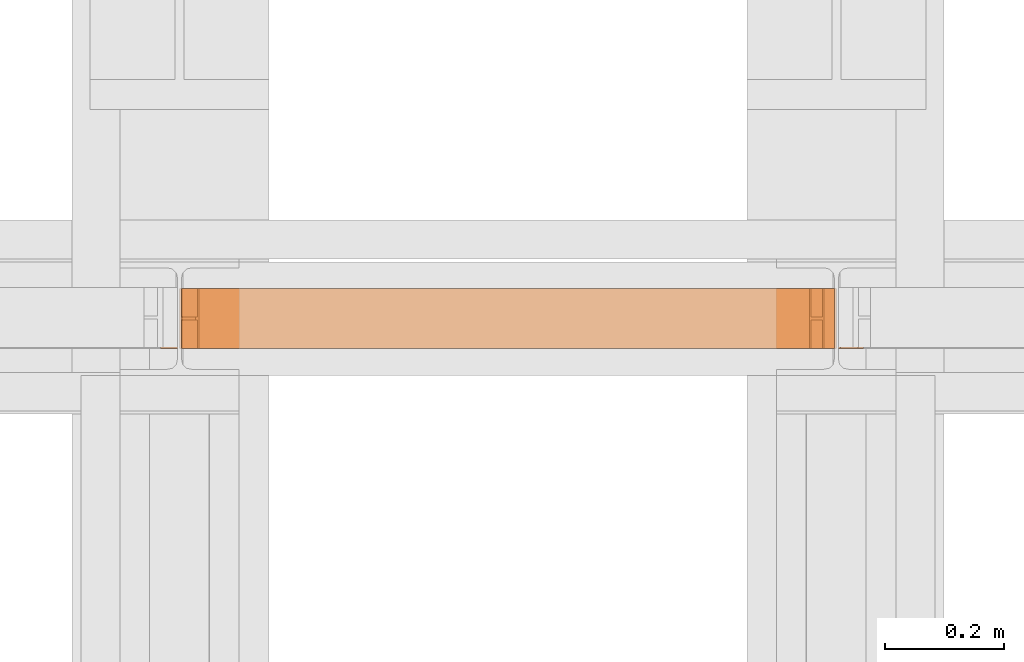
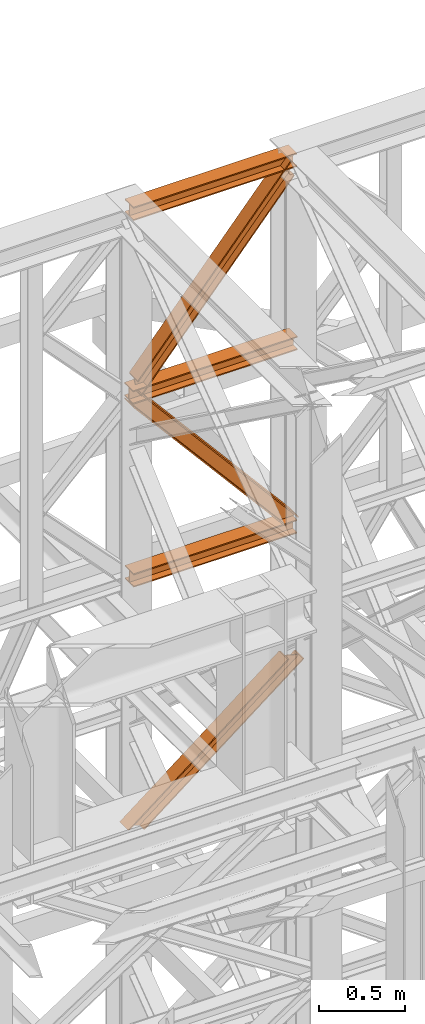
# One storey, part 172 of 208: 6 proxies.
"""IFC2X3 building model written with IfcOpenShell, lengths in millimetres."""

from ifc_helpers import new_model, entity, si_unit, converted_unit, frame, origin, origin_with_axes, place, context, subcontext, project, spatial, faceted_brep, element, save


model = new_model("IFC2X3")

# Units and contexts
model_context = context("Model", 3, precision=1e-05, world=origin())
plan_context = context("Plan", 3, precision=1e-05, world=origin())
body_context = subcontext(model_context, "Body", "Model", "MODEL_VIEW")
ifc_project = project(units=[si_unit("LENGTHUNIT", "METRE", prefix="MILLI"), converted_unit("PLANEANGLEUNIT", "DEGREE", entity("IfcPlaneAngleMeasure", 0.0174532925199433), si_unit("PLANEANGLEUNIT", "RADIAN"), dimensions=[0, 0, 0, 0, 0, 0, 0]), si_unit("AREAUNIT", "SQUARE_METRE"), si_unit("VOLUMEUNIT", "CUBIC_METRE")], contexts=[model_context, plan_context])

# Building, storey
building_placement = place(None, origin())
building = spatial("IfcBuilding", under=ifc_project, at=building_placement, CompositionType="COMPLEX")
storey_placement = place(building_placement, origin_with_axes())
storey = spatial("IfcBuildingStorey", under=building, at=storey_placement, Name="Geschoss", CompositionType="ELEMENT")

# Proxies
proxy_1_placement = place(storey_placement, frame((5498.369516902634, -13812.50587051042, 9710.105713222341), z_axis=(0.0, 0.0, 1.0), x_axis=(1.0, 0.0, 0.0)))
element("IfcBuildingElementProxy", 1, at=proxy_1_placement, inside=storey, context=body_context, shape_type="Brep", body=[
    faceted_brep([(1091.936120735611, 0.01000000000021828, 88.01000000000022), (1091.936120735611, 0.01000000000021828, 96.01000000000022), (1091.936120735611, 100.0100000000002, 96.01000000000022), (1091.936120735611, 100.0100000000002, 88.01000000000022), (1091.936120735611, 52.51000000000022, 88.01000000000022), (1091.936120735611, 52.51000000000022, 8.010000000000218), (1091.936120735611, 100.0100000000002, 8.010000000000218), (1091.936120735611, 100.0100000000002, 0.01000000000021828), (1091.936120735611, 0.01000000000021828, 0.01000000000021828), (1091.936120735611, 0.01000000000021828, 8.010000000000218), (1091.936120735611, 47.51000000000022, 8.010000000000218), (1091.936120735611, 47.51000000000022, 88.01000000000022), (1091.936120735611, 0.01000000000021828, 96.01000000000022), (1091.936120735611, 0.01000000000021828, 88.01000000000022), (0.009999999999308784, 0.01000000000385626, 88.01000000000022), (0.009999999999308784, 0.01000000000385626, 96.01000000000022), (1091.936120735611, 100.0100000000002, 96.01000000000022), (1091.936120735611, 0.01000000000021828, 96.01000000000022), (0.009999999999308784, 0.01000000000385626, 96.01000000000022), (0.009999999999308784, 100.0100000000039, 96.01000000000022), (1091.936120735611, 100.0100000000002, 88.01000000000022), (1091.936120735611, 100.0100000000002, 96.01000000000022), (0.009999999999308784, 100.0100000000039, 96.01000000000022), (0.009999999999308784, 100.0100000000039, 88.01000000000022), (1091.936120735611, 52.51000000000022, 88.01000000000022), (1091.936120735611, 100.0100000000002, 88.01000000000022), (0.009999999999308784, 100.0100000000039, 88.01000000000022), (0.009999999999308784, 52.51000000000386, 88.01000000000022), (1091.936120735611, 52.51000000000022, 8.010000000000218), (1091.936120735611, 52.51000000000022, 88.01000000000022), (0.009999999999308784, 52.51000000000386, 88.01000000000022), (0.009999999999308784, 52.51000000000386, 8.010000000000218), (1091.936120735611, 100.0100000000002, 8.010000000000218), (1091.936120735611, 52.51000000000022, 8.010000000000218), (0.009999999999308784, 52.51000000000386, 8.010000000000218), (0.009999999999308784, 100.0100000000039, 8.010000000000218), (1091.936120735611, 100.0100000000002, 0.01000000000021828), (1091.936120735611, 100.0100000000002, 8.010000000000218), (0.009999999999308784, 100.0100000000039, 8.010000000000218), (0.009999999999308784, 100.0100000000039, 0.01000000000021828), (1091.936120735611, 0.01000000000021828, 0.01000000000021828), (1091.936120735611, 100.0100000000002, 0.01000000000021828), (0.009999999999308784, 100.0100000000039, 0.01000000000021828), (0.009999999999308784, 0.01000000000385626, 0.01000000000021828), (1091.936120735611, 0.01000000000021828, 8.010000000000218), (1091.936120735611, 0.01000000000021828, 0.01000000000021828), (0.009999999999308784, 0.01000000000385626, 0.01000000000021828), (0.009999999999308784, 0.01000000000385626, 8.010000000000218), (1091.936120735611, 47.51000000000022, 8.010000000000218), (1091.936120735611, 0.01000000000021828, 8.010000000000218), (0.009999999999308784, 0.01000000000385626, 8.010000000000218), (0.009999999999308784, 47.51000000000386, 8.010000000000218), (1091.936120735611, 47.51000000000022, 88.01000000000022), (1091.936120735611, 47.51000000000022, 8.010000000000218), (0.009999999999308784, 47.51000000000386, 8.010000000000218), (0.009999999999308784, 47.51000000000386, 88.01000000000022), (1091.936120735611, 0.01000000000021828, 88.01000000000022), (1091.936120735611, 47.51000000000022, 88.01000000000022), (0.009999999999308784, 47.51000000000386, 88.01000000000022), (0.009999999999308784, 0.01000000000385626, 88.01000000000022), (0.009999999999308784, 0.01000000000385626, 88.01000000000022), (0.009999999999308784, 47.51000000000386, 88.01000000000022), (0.009999999999308784, 47.51000000000386, 8.010000000000218), (0.009999999999308784, 0.01000000000385626, 8.010000000000218), (0.009999999999308784, 0.01000000000385626, 0.01000000000021828), (0.009999999999308784, 100.0100000000039, 0.01000000000021828), (0.009999999999308784, 100.0100000000039, 8.010000000000218), (0.009999999999308784, 52.51000000000386, 8.010000000000218), (0.009999999999308784, 52.51000000000386, 88.01000000000022), (0.009999999999308784, 100.0100000000039, 88.01000000000022), (0.009999999999308784, 100.0100000000039, 96.01000000000022), (0.009999999999308784, 0.01000000000385626, 96.01000000000022)], [[[0, 1, 2, 3, 4, 5, 6, 7, 8, 9, 10, 11]], [[12, 13, 14, 15]], [[16, 17, 18, 19]], [[20, 21, 22, 23]], [[24, 25, 26, 27]], [[28, 29, 30, 31]], [[32, 33, 34, 35]], [[36, 37, 38, 39]], [[40, 41, 42, 43]], [[44, 45, 46, 47]], [[48, 49, 50, 51]], [[52, 53, 54, 55]], [[56, 57, 58, 59]], [[60, 61, 62, 63, 64, 65, 66, 67, 68, 69, 70, 71]]], orient=[[False], [False], [False], [False], [False], [False], [False], [False], [False], [False], [False], [False], [False], [False]]),
])
proxy_2_placement = place(storey_placement, frame((5496.504968595721, -13812.50587051042, 12300.47045114381), z_axis=(0.0, 0.0, 1.0), x_axis=(1.0, 0.0, 0.0)))
element("IfcBuildingElementProxy", 2, at=proxy_2_placement, inside=storey, context=body_context, shape_type="Brep", body=[
    faceted_brep([(1093.509999865889, 0.01000000000021828, 88.01000000000022), (1093.509999865889, 0.01000000000021828, 96.01000000000022), (1093.509999865889, 100.0100000000002, 96.01000000000022), (1093.509999865889, 100.0100000000002, 88.01000000000022), (1093.509999865889, 52.51000000000022, 88.01000000000022), (1093.509999865889, 52.51000000000022, 8.010000000000218), (1093.509999865889, 100.0100000000002, 8.010000000000218), (1093.509999865889, 100.0100000000002, 0.01000000000021828), (1093.509999865889, 0.01000000000021828, 0.01000000000021828), (1093.509999865889, 0.01000000000021828, 8.010000000000218), (1093.509999865889, 47.51000000000022, 8.010000000000218), (1093.509999865889, 47.51000000000022, 88.01000000000022), (1093.509999865889, 0.01000000000021828, 96.01000000000022), (1093.509999865889, 0.01000000000021828, 88.01000000000022), (0.01000000000021828, 0.01000000000385626, 88.01000000000022), (0.01000000000021828, 0.01000000000385626, 96.01000000000022), (1093.509999865889, 100.0100000000002, 96.01000000000022), (1093.509999865889, 0.01000000000021828, 96.01000000000022), (0.01000000000021828, 0.01000000000385626, 96.01000000000022), (0.01000000000021828, 100.0100000000039, 96.01000000000022), (1093.509999865889, 100.0100000000002, 88.01000000000022), (1093.509999865889, 100.0100000000002, 96.01000000000022), (0.01000000000021828, 100.0100000000039, 96.01000000000022), (0.01000000000021828, 100.0100000000039, 88.01000000000022), (1093.509999865889, 52.51000000000022, 88.01000000000022), (1093.509999865889, 100.0100000000002, 88.01000000000022), (0.01000000000021828, 100.0100000000039, 88.01000000000022), (0.01000000000021828, 52.51000000000386, 88.01000000000022), (1093.509999865889, 52.51000000000022, 8.010000000000218), (1093.509999865889, 52.51000000000022, 88.01000000000022), (0.01000000000021828, 52.51000000000386, 88.01000000000022), (0.01000000000021828, 52.51000000000386, 8.010000000000218), (1093.509999865889, 100.0100000000002, 8.010000000000218), (1093.509999865889, 52.51000000000022, 8.010000000000218), (0.01000000000021828, 52.51000000000386, 8.010000000000218), (0.01000000000021828, 100.0100000000039, 8.010000000000218), (1093.509999865889, 100.0100000000002, 0.01000000000021828), (1093.509999865889, 100.0100000000002, 8.010000000000218), (0.01000000000021828, 100.0100000000039, 8.010000000000218), (0.01000000000021828, 100.0100000000039, 0.01000000000021828), (1093.509999865889, 0.01000000000021828, 0.01000000000021828), (1093.509999865889, 100.0100000000002, 0.01000000000021828), (0.01000000000021828, 100.0100000000039, 0.01000000000021828), (0.01000000000021828, 0.01000000000385626, 0.01000000000021828), (1093.509999865889, 0.01000000000021828, 8.010000000000218), (1093.509999865889, 0.01000000000021828, 0.01000000000021828), (0.01000000000021828, 0.01000000000385626, 0.01000000000021828), (0.01000000000021828, 0.01000000000385626, 8.010000000000218), (1093.509999865889, 47.51000000000022, 8.010000000000218), (1093.509999865889, 0.01000000000021828, 8.010000000000218), (0.01000000000021828, 0.01000000000385626, 8.010000000000218), (0.01000000000021828, 47.51000000000386, 8.010000000000218), (1093.509999865889, 47.51000000000022, 88.01000000000022), (1093.509999865889, 47.51000000000022, 8.010000000000218), (0.01000000000021828, 47.51000000000386, 8.010000000000218), (0.01000000000021828, 47.51000000000386, 88.01000000000022), (1093.509999865889, 0.01000000000021828, 88.01000000000022), (1093.509999865889, 47.51000000000022, 88.01000000000022), (0.01000000000021828, 47.51000000000386, 88.01000000000022), (0.01000000000021828, 0.01000000000385626, 88.01000000000022), (0.01000000000021828, 0.01000000000385626, 88.01000000000022), (0.01000000000021828, 47.51000000000386, 88.01000000000022), (0.01000000000021828, 47.51000000000386, 8.010000000000218), (0.01000000000021828, 0.01000000000385626, 8.010000000000218), (0.01000000000021828, 0.01000000000385626, 0.01000000000021828), (0.01000000000021828, 100.0100000000039, 0.01000000000021828), (0.01000000000021828, 100.0100000000039, 8.010000000000218), (0.01000000000021828, 52.51000000000386, 8.010000000000218), (0.01000000000021828, 52.51000000000386, 88.01000000000022), (0.01000000000021828, 100.0100000000039, 88.01000000000022), (0.01000000000021828, 100.0100000000039, 96.01000000000022), (0.01000000000021828, 0.01000000000385626, 96.01000000000022)], [[[0, 1, 2, 3, 4, 5, 6, 7, 8, 9, 10, 11]], [[12, 13, 14, 15]], [[16, 17, 18, 19]], [[20, 21, 22, 23]], [[24, 25, 26, 27]], [[28, 29, 30, 31]], [[32, 33, 34, 35]], [[36, 37, 38, 39]], [[40, 41, 42, 43]], [[44, 45, 46, 47]], [[48, 49, 50, 51]], [[52, 53, 54, 55]], [[56, 57, 58, 59]], [[60, 61, 62, 63, 64, 65, 66, 67, 68, 69, 70, 71]]], orient=[[False], [False], [False], [False], [False], [False], [False], [False], [False], [False], [False], [False], [False], [False]]),
])
proxy_3_placement = place(storey_placement, frame((5493.254970018781, -13812.57439031789, 11004.87375573262), z_axis=(0.0, 0.0, 1.0), x_axis=(1.0, 0.0, 0.0)))
element("IfcBuildingElementProxy", 3, at=proxy_3_placement, inside=storey, context=body_context, shape_type="Brep", body=[
    faceted_brep([(1100.00999701977, 0.01000000000021828, 8.010000000000218), (1100.00999701977, 47.51000000000022, 8.010000000000218), (1100.00999701977, 47.51000000000022, 88.01000000000022), (1100.00999701977, 0.01000000000021828, 88.01000000000022), (1100.00999701977, 0.01000000000021828, 96.01000000000022), (1100.00999701977, 100.0100000000002, 96.01000000000022), (1100.00999701977, 100.0100000000002, 88.01000000000022), (1100.00999701977, 52.51000000000022, 88.01000000000022), (1100.00999701977, 52.51000000000022, 8.010000000000218), (1100.00999701977, 100.0100000000002, 8.010000000000218), (1100.00999701977, 100.0100000000002, 0.01000000000021828), (1100.00999701977, 0.01000000000021828, 0.01000000000021828), (1100.00999701977, 0.01000000000021828, 0.01000000000021828), (0.01000000000021828, 0.01000000000385626, 0.01000000000385626), (0.01000000000021828, 0.01000000000385626, 8.010000000003856), (1100.00999701977, 0.01000000000021828, 8.010000000000218), (1100.00999701977, 100.0100000000002, 0.01000000000021828), (0.01000000000021828, 100.0100000000039, 0.01000000000385626), (0.01000000000021828, 0.01000000000385626, 0.01000000000385626), (1100.00999701977, 0.01000000000021828, 0.01000000000021828), (1100.00999701977, 100.0100000000002, 8.010000000000218), (0.01000000000021828, 100.0100000000039, 8.010000000003856), (0.01000000000021828, 100.0100000000039, 0.01000000000385626), (1100.00999701977, 100.0100000000002, 0.01000000000021828), (1100.00999701977, 52.51000000000022, 8.010000000000218), (0.01000000000021828, 52.51000000000386, 8.010000000003856), (0.01000000000021828, 100.0100000000039, 8.010000000003856), (1100.00999701977, 100.0100000000002, 8.010000000000218), (1100.00999701977, 52.51000000000022, 88.01000000000022), (0.01000000000021828, 52.51000000000386, 88.01000000000386), (0.01000000000021828, 52.51000000000386, 8.010000000003856), (1100.00999701977, 52.51000000000022, 8.010000000000218), (1100.00999701977, 100.0100000000002, 88.01000000000022), (0.01000000000021828, 100.0100000000039, 88.01000000000386), (0.01000000000021828, 52.51000000000386, 88.01000000000386), (1100.00999701977, 52.51000000000022, 88.01000000000022), (1100.00999701977, 100.0100000000002, 96.01000000000022), (0.01000000000021828, 100.0100000000039, 96.01000000000386), (0.01000000000021828, 100.0100000000039, 88.01000000000386), (1100.00999701977, 100.0100000000002, 88.01000000000022), (1100.00999701977, 0.01000000000021828, 96.01000000000022), (0.01000000000021828, 0.01000000000385626, 96.01000000000386), (0.01000000000021828, 100.0100000000039, 96.01000000000386), (1100.00999701977, 100.0100000000002, 96.01000000000022), (1100.00999701977, 0.01000000000021828, 88.01000000000022), (0.01000000000021828, 0.01000000000385626, 88.01000000000386), (0.01000000000021828, 0.01000000000385626, 96.01000000000386), (1100.00999701977, 0.01000000000021828, 96.01000000000022), (1100.00999701977, 47.51000000000022, 88.01000000000022), (0.01000000000021828, 47.51000000000386, 88.01000000000386), (0.01000000000021828, 0.01000000000385626, 88.01000000000386), (1100.00999701977, 0.01000000000021828, 88.01000000000022), (1100.00999701977, 47.51000000000022, 8.010000000000218), (0.01000000000021828, 47.51000000000386, 8.010000000003856), (0.01000000000021828, 47.51000000000386, 88.01000000000386), (1100.00999701977, 47.51000000000022, 88.01000000000022), (1100.00999701977, 0.01000000000021828, 8.010000000000218), (0.01000000000021828, 0.01000000000385626, 8.010000000003856), (0.01000000000021828, 47.51000000000386, 8.010000000003856), (1100.00999701977, 47.51000000000022, 8.010000000000218), (0.01000000000021828, 0.01000000000385626, 8.010000000003856), (0.01000000000021828, 0.01000000000385626, 0.01000000000385626), (0.01000000000021828, 100.0100000000039, 0.01000000000385626), (0.01000000000021828, 100.0100000000039, 8.010000000003856), (0.01000000000021828, 52.51000000000386, 8.010000000003856), (0.01000000000021828, 52.51000000000386, 88.01000000000386), (0.01000000000021828, 100.0100000000039, 88.01000000000386), (0.01000000000021828, 100.0100000000039, 96.01000000000386), (0.01000000000021828, 0.01000000000385626, 96.01000000000386), (0.01000000000021828, 0.01000000000385626, 88.01000000000386), (0.01000000000021828, 47.51000000000386, 88.01000000000386), (0.01000000000021828, 47.51000000000386, 8.010000000003856)], [[[0, 1, 2, 3, 4, 5, 6, 7, 8, 9, 10, 11]], [[12, 13, 14, 15]], [[16, 17, 18, 19]], [[20, 21, 22, 23]], [[24, 25, 26, 27]], [[28, 29, 30, 31]], [[32, 33, 34, 35]], [[36, 37, 38, 39]], [[40, 41, 42, 43]], [[44, 45, 46, 47]], [[48, 49, 50, 51]], [[52, 53, 54, 55]], [[56, 57, 58, 59]], [[60, 61, 62, 63, 64, 65, 66, 67, 68, 69, 70, 71]]], orient=[[False], [False], [False], [False], [False], [False], [False], [False], [False], [False], [False], [False], [False], [False]]),
])
proxy_4_placement = place(storey_placement, frame((5525.561542650394, -13812.50587051044, 11042.17664862876), z_axis=(0.0, 0.0, 1.0), x_axis=(1.0, 0.0, 0.0)))
element("IfcBuildingElementProxy", 4, at=proxy_4_placement, inside=storey, context=body_context, shape_type="Brep", body=[
    faceted_brep([(0.01000000000567525, 0.01000000000749424, 117.4042142077469), (1022.999357737781, 0.01000000002204615, 1317.000909618933), (1024.974904555365, 0.01000000002204615, 1307.218058434957), (1.985546817591967, 0.01000000000021828, 107.6213630237635), (0.01000000000021828, 100.0100000000002, 117.4042142077396), (1022.999357737781, 100.0100000000221, 1317.000909618933), (1022.999357737781, 0.01000000002204615, 1317.000909618933), (0.01000000000567525, 0.01000000000749424, 117.4042142077469), (1.985546817584691, 100.0100000000002, 107.6213630237598), (1024.974904555364, 100.0100000000221, 1307.218058434964), (1022.999357737781, 100.0100000000221, 1317.000909618933), (0.01000000000021828, 100.0100000000002, 117.4042142077396), (1.985546817584691, 52.51000000000022, 107.6213630237562), (1024.974904555365, 52.51000000002205, 1307.218058434957), (1024.974904555364, 100.0100000000221, 1307.218058434964), (1.985546817584691, 100.0100000000002, 107.6213630237598), (21.74101499342942, 52.51000000000749, 9.792851183972743), (1044.730372731206, 52.51000000002205, 1209.389546595181), (1024.974904555365, 52.51000000002205, 1307.218058434957), (1.985546817584691, 52.51000000000022, 107.6213630237562), (21.74101499342942, 100.0100000000075, 9.792851183976381), (1044.730372731208, 100.0100000000221, 1209.389546595177), (1044.730372731206, 52.51000000002205, 1209.389546595181), (21.74101499342942, 52.51000000000749, 9.792851183972743), (23.71656181101207, 100.0100000000075, 0.01000000000385626), (1046.705919548793, 100.0100000000221, 1199.606695411198), (1044.730372731208, 100.0100000000221, 1209.389546595177), (21.74101499342942, 100.0100000000075, 9.792851183976381), (23.71656181101935, 0.01000000000749424, 0.01000000000021828), (1046.705919548793, 0.01000000002204615, 1199.606695411198), (1046.705919548793, 100.0100000000221, 1199.606695411198), (23.71656181101207, 100.0100000000075, 0.01000000000385626), (21.74101499342942, 0.01000000000021828, 9.792851183972743), (1044.730372731208, 0.01000000002204615, 1209.389546595174), (1046.705919548793, 0.01000000002204615, 1199.606695411198), (23.71656181101935, 0.01000000000749424, 0.01000000000021828), (21.74101499342942, 47.51000000000749, 9.792851183976381), (1044.730372731208, 47.51000000002205, 1209.389546595174), (1044.730372731208, 0.01000000002204615, 1209.389546595174), (21.74101499342942, 0.01000000000021828, 9.792851183972743), (1.985546817591967, 47.51000000000022, 107.6213630237562), (1024.974904555365, 47.51000000002205, 1307.218058434957), (1044.730372731208, 47.51000000002205, 1209.389546595174), (21.74101499342942, 47.51000000000749, 9.792851183976381), (1.985546817591967, 0.01000000000021828, 107.6213630237635), (1024.974904555365, 0.01000000002204615, 1307.218058434957), (1024.974904555365, 47.51000000002205, 1307.218058434957), (1.985546817591967, 47.51000000000022, 107.6213630237562), (1.985546817591967, 0.01000000000021828, 107.6213630237635), (1.985546817591967, 47.51000000000022, 107.6213630237562), (21.74101499342942, 47.51000000000749, 9.792851183976381), (21.74101499342942, 0.01000000000021828, 9.792851183972743), (23.71656181101935, 0.01000000000749424, 0.01000000000021828), (23.71656181101207, 100.0100000000075, 0.01000000000385626), (21.74101499342942, 100.0100000000075, 9.792851183976381), (21.74101499342942, 52.51000000000749, 9.792851183972743), (1.985546817584691, 52.51000000000022, 107.6213630237562), (1.985546817584691, 100.0100000000002, 107.6213630237598), (0.01000000000021828, 100.0100000000002, 117.4042142077396), (0.01000000000567525, 0.01000000000749424, 117.4042142077469), (1022.999357737781, 0.01000000002204615, 1317.000909618933), (1022.999357737781, 100.0100000000221, 1317.000909618933), (1024.974904555364, 100.0100000000221, 1307.218058434964), (1024.974904555365, 52.51000000002205, 1307.218058434957), (1044.730372731206, 52.51000000002205, 1209.389546595181), (1044.730372731208, 100.0100000000221, 1209.389546595177), (1046.705919548793, 100.0100000000221, 1199.606695411198), (1046.705919548793, 0.01000000002204615, 1199.606695411198), (1044.730372731208, 0.01000000002204615, 1209.389546595174), (1044.730372731208, 47.51000000002205, 1209.389546595174), (1024.974904555365, 47.51000000002205, 1307.218058434957), (1024.974904555365, 0.01000000002204615, 1307.218058434957)], [[[0, 1, 2, 3]], [[4, 5, 6, 7]], [[8, 9, 10, 11]], [[12, 13, 14, 15]], [[16, 17, 18, 19]], [[20, 21, 22, 23]], [[24, 25, 26, 27]], [[28, 29, 30, 31]], [[32, 33, 34, 35]], [[36, 37, 38, 39]], [[40, 41, 42, 43]], [[44, 45, 46, 47]], [[48, 49, 50, 51, 52, 53, 54, 55, 56, 57, 58, 59]], [[60, 61, 62, 63, 64, 65, 66, 67, 68, 69, 70, 71]]], orient=[[False], [False], [False], [False], [False], [False], [False], [False], [False], [False], [False], [False], [False], [False]]),
])
proxy_5_placement = place(storey_placement, frame((5493.758468060874, -13812.50587051042, 9774.316211919699), z_axis=(0.0, 0.0, 1.0), x_axis=(1.0, 0.0, 0.0)))
element("IfcBuildingElementProxy", 5, at=proxy_5_placement, inside=storey, context=body_context, shape_type="Brep", body=[
    faceted_brep([(2.426940056748208, 0.01000000000021828, 1217.828617330184), (1022.2706810979, 0.01000000001477019, 18.26943825006129), (1009.048721810295, 0.01000000000021828, 21.6863571305239), (0.01000000000112777, 0.01000000000021828, 1208.47613219698), (0.01000000000112777, 0.01000000000021828, 1208.47613219698), (1009.048721810295, 0.01000000000021828, 21.6863571305239), (1009.048721810294, 100.0100000000075, 21.6863571305239), (0.01000000000021828, 100.0100000000075, 1208.47613219698), (0.01000000000021828, 100.0100000000075, 1208.47613219698), (1009.048721810294, 100.0100000000075, 21.6863571305239), (1022.2706810979, 100.0100000000148, 18.26943825006129), (2.426940056748208, 100.0100000000002, 1217.828617330184), (2.426940056748208, 100.0100000000002, 1217.828617330184), (1022.2706810979, 100.0100000000148, 18.26943825006129), (1022.270681097911, 52.51000000001477, 18.26943825005037), (2.426940056747299, 52.51000000000749, 1217.828617330177), (2.426940056747299, 52.51000000000749, 1217.828617330177), (1022.270681097911, 52.51000000001477, 18.26943825005037), (1092.926601710209, 52.51000000001477, 0.01000000000385626), (1104.115671197322, 52.51000000001477, 43.30673205604217), (29.4021868200216, 52.51000000000022, 1308.237943105234), (26.00163355986842, 52.51000000000022, 1309.052216315255), (29.4021868200216, 52.51000000000022, 1308.237943105234), (1104.115671197322, 52.51000000001477, 43.30673205604217), (1104.115671197322, 100.0100000000075, 43.30673205604217), (29.40218682002069, 100.0100000000002, 1308.237943105227), (29.40218682002069, 100.0100000000002, 1308.237943105227), (1104.115671197322, 100.0100000000075, 43.30673205604217), (1106.51967248383, 100.0100000000075, 52.60914989197227), (42.44786863919762, 100.0100000000002, 1305.114113422484), (42.44786863919762, 100.0100000000002, 1305.114113422484), (1106.51967248383, 100.0100000000075, 52.60914989197227), (1106.51967248383, 0.01000000001477019, 52.60914989197227), (42.44786863919762, 0.01000000000021828, 1305.114113422484), (42.44786863919762, 0.01000000000021828, 1305.114113422484), (1106.51967248383, 0.01000000001477019, 52.60914989197227), (1104.115671197322, 0.01000000001477019, 43.30673205604217), (29.4021868200216, 0.01000000000021828, 1308.237943105234), (29.4021868200216, 0.01000000000021828, 1308.237943105234), (1104.115671197322, 0.01000000001477019, 43.30673205604217), (1104.115671197321, 47.51000000001477, 43.30673205603853), (29.40218682002069, 47.51000000000022, 1308.237943105227), (29.40218682002069, 47.51000000000022, 1308.237943105227), (1104.115671197321, 47.51000000001477, 43.30673205603853), (1092.926601710224, 47.51000000002205, 0.01000000000021828), (1022.2706810979, 47.51000000001477, 18.26943825006129), (2.426940056748208, 47.51000000000022, 1217.828617330184), (26.00163355986842, 47.51000000000022, 1309.052216315251), (2.426940056748208, 47.51000000000022, 1217.828617330184), (1022.2706810979, 47.51000000001477, 18.26943825006129), (1022.2706810979, 0.01000000001477019, 18.26943825006129), (2.426940056748208, 0.01000000000021828, 1217.828617330184), (26.00163355986842, 52.51000000000022, 1309.052216315255), (29.4021868200216, 52.51000000000022, 1308.237943105234), (29.40218682002069, 100.0100000000002, 1308.237943105227), (42.44786863919762, 100.0100000000002, 1305.114113422484), (42.44786863919762, 0.01000000000021828, 1305.114113422484), (29.4021868200216, 0.01000000000021828, 1308.237943105234), (29.40218682002069, 47.51000000000022, 1308.237943105227), (26.00163355986842, 47.51000000000022, 1309.052216315251), (1092.926601710224, 47.51000000002205, 0.01000000000021828), (1104.115671197321, 47.51000000001477, 43.30673205603853), (1104.115671197322, 0.01000000001477019, 43.30673205604217), (1106.51967248383, 0.01000000001477019, 52.60914989197227), (1106.51967248383, 100.0100000000075, 52.60914989197227), (1104.115671197322, 100.0100000000075, 43.30673205604217), (1104.115671197322, 52.51000000001477, 43.30673205604217), (1092.926601710209, 52.51000000001477, 0.01000000000385626), (1022.2706810979, 0.01000000001477019, 18.26943825006129), (1022.2706810979, 47.51000000001477, 18.26943825006129), (1092.926601710224, 47.51000000002205, 0.01000000000021828), (1092.926601710209, 52.51000000001477, 0.01000000000385626), (1022.270681097911, 52.51000000001477, 18.26943825005037), (1022.2706810979, 100.0100000000148, 18.26943825006129), (1009.048721810294, 100.0100000000075, 21.6863571305239), (1009.048721810295, 0.01000000000021828, 21.6863571305239), (0.01000000000112777, 0.01000000000021828, 1208.47613219698), (0.01000000000021828, 100.0100000000075, 1208.47613219698), (2.426940056748208, 100.0100000000002, 1217.828617330184), (2.426940056747299, 52.51000000000749, 1217.828617330177), (26.00163355986842, 52.51000000000022, 1309.052216315255), (26.00163355986842, 47.51000000000022, 1309.052216315251), (2.426940056748208, 47.51000000000022, 1217.828617330184), (2.426940056748208, 0.01000000000021828, 1217.828617330184)], [[[0, 1, 2, 3]], [[4, 5, 6, 7]], [[8, 9, 10, 11]], [[12, 13, 14, 15]], [[16, 17, 18, 19, 20, 21]], [[22, 23, 24, 25]], [[26, 27, 28, 29]], [[30, 31, 32, 33]], [[34, 35, 36, 37]], [[38, 39, 40, 41]], [[42, 43, 44, 45, 46, 47]], [[48, 49, 50, 51]], [[52, 53, 54, 55, 56, 57, 58, 59]], [[60, 61, 62, 63, 64, 65, 66, 67]], [[68, 69, 70, 71, 72, 73, 74, 75]], [[76, 77, 78, 79, 80, 81, 82, 83]]], orient=[[False], [False], [False], [False], [False], [False], [False], [False], [False], [False], [False], [False], [False], [False], [False], [False]]),
])
proxy_6_placement = place(storey_placement, frame((5461.52504175254, -13812.57439031789, 7974.544933532825), z_axis=(0.0, 0.0, 1.0), x_axis=(1.0, 0.0, 0.0)))
element("IfcBuildingElementProxy", 6, at=proxy_6_placement, inside=storey, context=body_context, shape_type="Brep", body=[
    faceted_brep([(102.3304620042309, 0.01000000000021828, 2.698394179888055), (1167.71864773611, 0.01000000000021828, 836.8112103120347), (1177.020507918311, 0.01000000000021828, 834.1228161321469), (111.6323221864332, 0.01000000000021828, 0.01000000000021828), (111.6323221864332, 0.01000000000021828, 0.01000000000021828), (1177.020507918311, 0.01000000000021828, 834.1228161321469), (1177.020507918312, 100.0100000000002, 834.1228161321469), (111.6323221864332, 100.0100000000002, 0.01000000000021828), (111.6323221864332, 100.0100000000002, 0.01000000000021828), (1177.020507918312, 100.0100000000002, 834.1228161321469), (1167.71864773611, 100.0100000000002, 836.8112103120347), (102.3304620042309, 100.0100000000002, 2.698394179888055), (102.3304620042309, 100.0100000000002, 2.698394179888055), (1167.71864773611, 100.0100000000002, 836.8112103120347), (1167.71864773611, 52.51000000000022, 836.8112103120347), (102.3304620042309, 52.51000000000022, 2.698394179888055), (102.3304620042309, 52.51000000000022, 2.698394179888055), (1167.71864773611, 52.51000000000022, 836.8112103120347), (1074.70004591408, 52.51000000000022, 863.6951521109131), (9.311860182202508, 52.51000000000022, 29.58233597875915), (9.311860182202508, 52.51000000000022, 29.58233597875915), (1074.70004591408, 52.51000000000022, 863.6951521109131), (1074.70004591408, 100.0100000000002, 863.6951521109131), (9.311860182204327, 100.0100000000002, 29.58233597875915), (9.311860182204327, 100.0100000000002, 29.58233597875915), (1074.70004591408, 100.0100000000002, 863.6951521109131), (1065.398185731876, 100.0100000000002, 866.3835462907937), (0.01000000000021828, 100.0100000000002, 32.27073015864698), (0.01000000000021828, 100.0100000000002, 32.27073015864698), (1065.398185731876, 100.0100000000002, 866.3835462907937), (1065.398185731878, 0.01000000000021828, 866.383546290801), (0.01000000000021828, 0.01000000000021828, 32.27073015864698), (0.01000000000021828, 0.01000000000021828, 32.27073015864698), (1065.398185731878, 0.01000000000021828, 866.383546290801), (1074.70004591408, 0.01000000000021828, 863.6951521109131), (9.311860182202508, 0.01000000000021828, 29.58233597875915), (9.311860182202508, 0.01000000000021828, 29.58233597875915), (1074.70004591408, 0.01000000000021828, 863.6951521109131), (1074.700045914082, 47.51000000000022, 863.6951521109131), (9.311860182204327, 47.51000000000022, 29.58233597875915), (9.311860182204327, 47.51000000000022, 29.58233597875915), (1074.700045914082, 47.51000000000022, 863.6951521109131), (1167.71864773611, 47.51000000000022, 836.8112103120347), (102.3304620042309, 47.51000000000022, 2.698394179888055), (102.3304620042309, 47.51000000000022, 2.698394179888055), (1167.71864773611, 47.51000000000022, 836.8112103120347), (1167.71864773611, 0.01000000000021828, 836.8112103120347), (102.3304620042309, 0.01000000000021828, 2.698394179888055), (1167.71864773611, 0.01000000000021828, 836.8112103120347), (1167.71864773611, 47.51000000000022, 836.8112103120347), (1074.700045914082, 47.51000000000022, 863.6951521109131), (1074.70004591408, 0.01000000000021828, 863.6951521109131), (1065.398185731878, 0.01000000000021828, 866.383546290801), (1065.398185731876, 100.0100000000002, 866.3835462907937), (1074.70004591408, 100.0100000000002, 863.6951521109131), (1074.70004591408, 52.51000000000022, 863.6951521109131), (1167.71864773611, 52.51000000000022, 836.8112103120347), (1167.71864773611, 100.0100000000002, 836.8112103120347), (1177.020507918312, 100.0100000000002, 834.1228161321469), (1177.020507918311, 0.01000000000021828, 834.1228161321469), (111.6323221864332, 0.01000000000021828, 0.01000000000021828), (111.6323221864332, 100.0100000000002, 0.01000000000021828), (102.3304620042309, 100.0100000000002, 2.698394179888055), (102.3304620042309, 52.51000000000022, 2.698394179888055), (9.311860182202508, 52.51000000000022, 29.58233597875915), (9.311860182204327, 100.0100000000002, 29.58233597875915), (0.01000000000021828, 100.0100000000002, 32.27073015864698), (0.01000000000021828, 0.01000000000021828, 32.27073015864698), (9.311860182202508, 0.01000000000021828, 29.58233597875915), (9.311860182204327, 47.51000000000022, 29.58233597875915), (102.3304620042309, 47.51000000000022, 2.698394179888055), (102.3304620042309, 0.01000000000021828, 2.698394179888055)], [[[0, 1, 2, 3]], [[4, 5, 6, 7]], [[8, 9, 10, 11]], [[12, 13, 14, 15]], [[16, 17, 18, 19]], [[20, 21, 22, 23]], [[24, 25, 26, 27]], [[28, 29, 30, 31]], [[32, 33, 34, 35]], [[36, 37, 38, 39]], [[40, 41, 42, 43]], [[44, 45, 46, 47]], [[48, 49, 50, 51, 52, 53, 54, 55, 56, 57, 58, 59]], [[60, 61, 62, 63, 64, 65, 66, 67, 68, 69, 70, 71]]], orient=[[False], [False], [False], [False], [False], [False], [False], [False], [False], [False], [False], [False], [False], [False]]),
])

save(model, "model.ifc")
